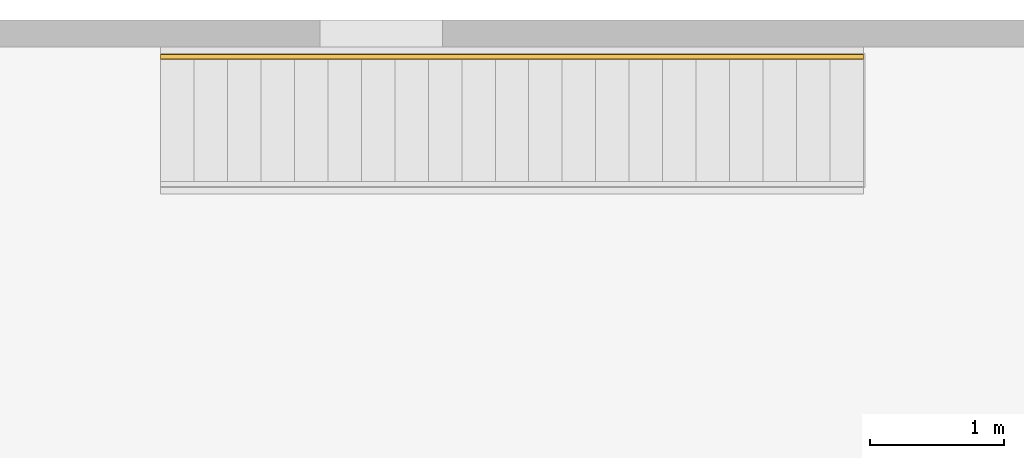
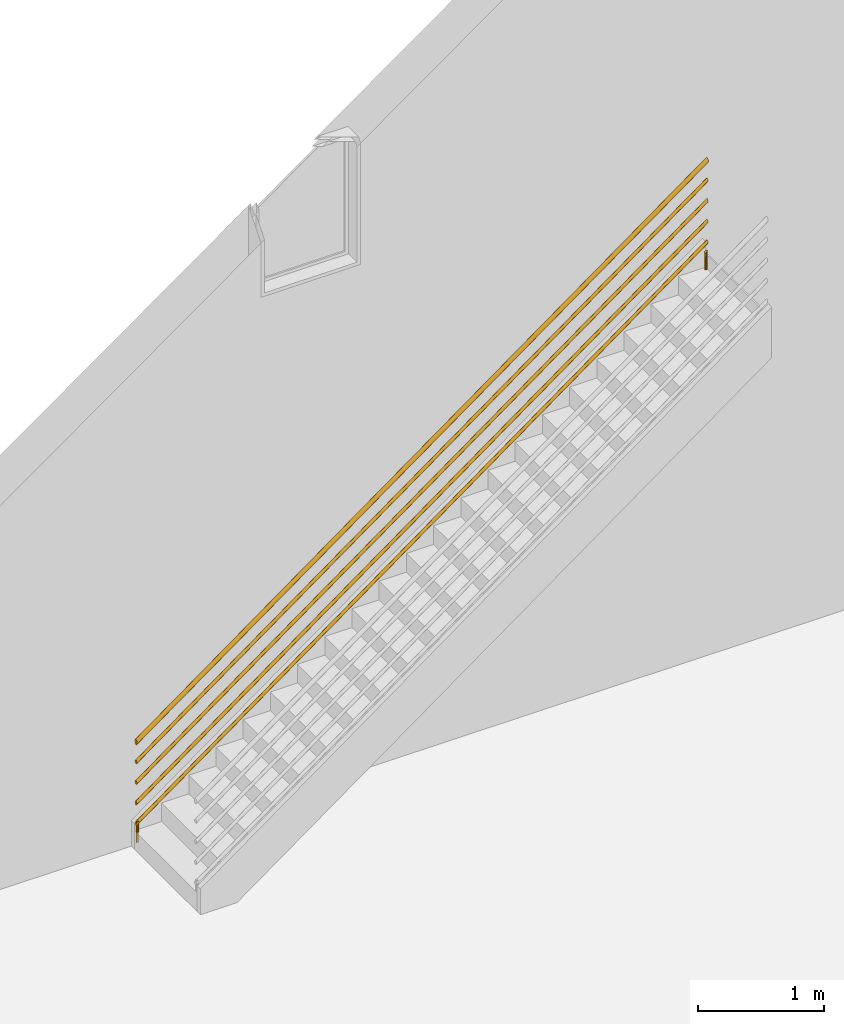
# One storey, part 4 of 4: 1 railing, 1 element without a shape of its own.
"""IFC4 building model written with IfcOpenShell, lengths in millimetres."""

from ifc_helpers import new_model, entity, si_unit, converted_unit, derived_unit, direction, frame, origin, place, context, subcontext, project, spatial, polygons, element, aggregate, save


model = new_model("IFC4")

# Units and contexts
model_context = context("Model", 3, precision=0.01, world=origin(), true_north=direction((6.12303176911189e-17, 1.0)))
body_context = subcontext(model_context, "Body", "Model", "MODEL_VIEW")
ifc_project = project(units=[si_unit("LENGTHUNIT", "METRE", prefix="MILLI"), si_unit("AREAUNIT", "SQUARE_METRE"), si_unit("VOLUMEUNIT", "CUBIC_METRE"), converted_unit("PLANEANGLEUNIT", "DEGREE", entity("IfcRatioMeasure", 0.0174532925199433), si_unit("PLANEANGLEUNIT", "RADIAN"), dimensions=[0, 0, 0, 0, 0, 0, 0]), si_unit("MASSUNIT", "GRAM", prefix="KILO"), derived_unit("MASSDENSITYUNIT", [(si_unit("MASSUNIT", "GRAM", prefix="KILO"), 1), (si_unit("LENGTHUNIT", "METRE"), -3)]), si_unit("TIMEUNIT", "SECOND"), si_unit("FREQUENCYUNIT", "HERTZ"), si_unit("THERMODYNAMICTEMPERATUREUNIT", "DEGREE_CELSIUS"), derived_unit("THERMALTRANSMITTANCEUNIT", [(si_unit("MASSUNIT", "GRAM", prefix="KILO"), 1), (si_unit("THERMODYNAMICTEMPERATUREUNIT", "KELVIN"), -1), (si_unit("TIMEUNIT", "SECOND"), -3)]), derived_unit("VOLUMETRICFLOWRATEUNIT", [(si_unit("LENGTHUNIT", "METRE"), 3), (si_unit("TIMEUNIT", "SECOND"), -1)]), si_unit("ELECTRICCURRENTUNIT", "AMPERE"), si_unit("ELECTRICVOLTAGEUNIT", "VOLT"), si_unit("POWERUNIT", "WATT"), si_unit("FORCEUNIT", "NEWTON", prefix="KILO"), si_unit("ILLUMINANCEUNIT", "LUX"), si_unit("LUMINOUSFLUXUNIT", "LUMEN"), si_unit("LUMINOUSINTENSITYUNIT", "CANDELA"), derived_unit("USERDEFINED", [(si_unit("MASSUNIT", "GRAM", prefix="KILO"), -1), (si_unit("LENGTHUNIT", "METRE"), -2), (si_unit("TIMEUNIT", "SECOND"), 3), (si_unit("LUMINOUSFLUXUNIT", "LUMEN"), 1)]), derived_unit("LINEARVELOCITYUNIT", [(si_unit("LENGTHUNIT", "METRE"), 1), (si_unit("TIMEUNIT", "SECOND"), -1)]), si_unit("PRESSUREUNIT", "PASCAL"), derived_unit("USERDEFINED", [(si_unit("LENGTHUNIT", "METRE"), -2), (si_unit("MASSUNIT", "GRAM", prefix="KILO"), 1), (si_unit("TIMEUNIT", "SECOND"), -2)])], contexts=[model_context])

# Site, building, storey
site_placement = place(None, origin())
site = spatial("IfcSite", under=ifc_project, at=site_placement, CompositionType="ELEMENT")
building_placement = place(site_placement, origin())
building = spatial("IfcBuilding", under=site, at=building_placement, CompositionType="ELEMENT")
storey_placement = place(building_placement, origin())
storey = spatial("IfcBuildingStorey", under=building, at=storey_placement, CompositionType="ELEMENT", Elevation=0.0)

# Stair, railing
stair_placement = place(storey_placement, origin())
stair = element("IfcStair", 1, at=stair_placement, inside=storey, Name="Assembled Stair:Stair", PredefinedType="NOTDEFINED")
railing_placement = place(stair_placement, frame((-1616.29690804862, 3783.31152440017, 81.8181818181819)))
railing = element("IfcRailing", 2, at=railing_placement, Name="Railing:900mm", ObjectType="Railing:900mm", PredefinedType="NOTDEFINED", context=body_context, shape_type="Tessellation", body=[
    polygons([(5238.77409890227, 34.0952722359161, 3909.09090909091), (5244.19764564124, 32.8573830846967, 3913.03530671925), (5248.54699243312, 29.3888947591506, 3916.19846802244), (5250.96069780455, 24.3767839103703, 3917.95389011074), (5250.96069780455, 18.8137605614627, 3917.95389011074), (5248.54699243312, 13.8016497126824, 3916.19846802244), (5244.19764564124, 10.3331613871363, 3913.03530671925), (5238.77409890227, 9.09527223591636, 3909.09090909091), (5238.77409890227, 9.09527223591636, 3736.36363636364), (5245.02409890227, 10.7699546886106, 3736.36363636364), (5249.59941644958, 15.3452722359166, 3736.36363636364), (5251.27409890227, 21.5952722359162, 3736.36363636364), (5249.59941644958, 27.8452722359164, 3736.36363636364), (5245.02409890227, 32.4205897832218, 3736.36363636364), (5238.77409890227, 34.0952722359161, 3736.36363636364), (5232.52409890227, 32.4205897832218, 3736.36363636364), (5227.94878135497, 27.8452722359164, 3736.36363636364), (5226.27409890227, 21.5952722359162, 3736.36363636364), (5227.94878135497, 15.3452722359166, 3736.36363636364), (5232.52409890227, 10.7699546886106, 3736.36363636364), (5233.3505521633, 10.3331613871363, 3905.14651146257), (5229.00120537142, 13.8016497126819, 3901.98335015938), (5226.5875, 18.8137605614622, 3900.22792807107), (5226.5875, 24.3767839103703, 3900.22792807107), (5229.00120537142, 29.3888947591506, 3901.98335015938), (5233.3505521633, 32.8573830846962, 3905.14651146257)], [[[2, 13, 14]], [[2, 14, 1]], [[13, 2, 3]], [[25, 24, 23, 22, 21, 8, 7, 6, 5, 4, 3, 2, 1, 26]], [[13, 3, 4]], [[4, 12, 13]], [[9, 20, 19, 18, 17, 16, 15, 14, 13, 12, 11, 10]], [[1, 14, 15]], [[15, 26, 1]], [[15, 16, 26]], [[4, 5, 12]], [[11, 12, 5]], [[10, 11, 7]], [[6, 11, 5]], [[7, 11, 6]], [[8, 9, 10]], [[7, 8, 10]], [[9, 8, 21]], [[21, 20, 9]], [[22, 19, 20]], [[19, 22, 23]], [[22, 20, 21]], [[23, 24, 18]], [[23, 18, 19]], [[17, 18, 24]], [[16, 17, 25]], [[17, 24, 25]], [[26, 16, 25]]], closed=True),
    polygons([(13.7740989022728, 9.09527223593314, 209.09090909091), (13.7740989022728, 9.09527223593314, -1.69197988952874e-14), (19.1976456412423, 10.3331613871525, -1.69197988952874e-14), (23.5469924331231, 13.8016497126987, -1.69197988952874e-14), (25.9606978045457, 18.813760561479, -1.69197988952874e-14), (25.9606978045457, 24.376783910387, -1.69197988952874e-14), (23.5469924331231, 29.3888947591674, -1.69197988952874e-14), (19.1976456412423, 32.857383084713, -1.69197988952874e-14), (13.7740989022728, 34.0952722359329, -1.69197988952874e-14), (13.7740989022728, 34.0952722359329, 209.09090909091), (19.1976456412423, 32.857383084713, 209.09090909091), (23.5469924331231, 29.3888947591674, 209.09090909091), (25.9606978045457, 24.376783910387, 209.09090909091), (25.9606978045457, 18.813760561479, 209.09090909091), (23.5469924331231, 13.8016497126987, 209.09090909091), (19.1976456412423, 10.3331613871525, 209.09090909091), (8.3505521633033, 32.857383084713, -1.69197988952874e-14), (4.00120537142245, 29.3888947591674, -1.69197988952874e-14), (1.58749999999991, 24.376783910387, -1.69197988952874e-14), (1.58749999999991, 18.813760561479, -1.69197988952874e-14), (4.00120537142245, 13.8016497126987, -1.69197988952874e-14), (8.3505521633033, 10.333161387153, -1.69197988952874e-14), (8.3505521633033, 10.333161387153, 209.09090909091), (4.00120537142245, 13.8016497126987, 209.09090909091), (1.58749999999991, 18.813760561479, 209.09090909091), (1.58749999999991, 24.376783910387, 209.09090909091), (4.00120537142245, 29.3888947591674, 209.09090909091), (8.3505521633033, 32.857383084713, 209.09090909091)], [[[8, 9, 10, 11]], [[7, 8, 11, 12]], [[3, 4, 15, 16]], [[9, 17, 28, 10]], [[26, 25, 24, 23, 1, 16, 15, 14, 13, 12, 11, 10, 28, 27]], [[13, 6, 7, 12]], [[13, 14, 5, 6]], [[4, 5, 14, 15]], [[18, 17, 9, 8, 7, 6, 5, 4, 3, 2, 22, 21, 20, 19]], [[2, 3, 16, 1]], [[22, 2, 1, 23]], [[23, 24, 21, 22]], [[21, 24, 25, 20]], [[25, 26, 19, 20]], [[18, 19, 26, 27]], [[17, 18, 27, 28]]], closed=True),
    polygons([(1.27409890227292, 6.59527223593317, 781.452540215361), (1.27409890227292, 7.10638484159716, 786.252976045899), (1.27409890227292, 8.60489117916664, 790.726270107681), (1.27409890227292, 10.9886705181346, 794.567574802864), (1.27409890227292, 14.0952722359331, 797.515111564529), (1.27409890227292, 17.712986559395, 799.368010633402), (1.27409890227292, 21.595272235933, 800.0), (1.27409890227292, 25.477557912471, 799.368010633402), (1.27409890227292, 29.0952722359329, 797.515111564529), (1.27409890227292, 32.2018739537314, 794.567574802865), (1.27409890227292, 34.5856532926994, 790.726270107681), (1.27409890227292, 36.0841596302689, 786.252976045899), (1.27409890227292, 36.5952722359328, 781.452540215361), (1.27409890227292, 36.0841596302689, 776.652104384824), (1.27409890227292, 34.5856532926999, 772.178810323042), (1.27409890227292, 32.2018739537314, 768.337505627858), (1.27409890227292, 29.0952722359329, 765.389968866194), (1.27409890227292, 25.477557912471, 763.53706979732), (1.27409890227292, 21.595272235933, 762.905080430722), (1.27409890227292, 17.7129865593955, 763.53706979732), (1.27409890227292, 14.0952722359331, 765.389968866193), (1.27409890227292, 10.9886705181346, 768.337505627858), (1.27409890227292, 8.60489117916664, 772.178810323042), (1.27409890227292, 7.10638484159716, 776.652104384823), (5251.27409890227, 6.59527223591639, 4599.63435839718), (5251.27409890227, 7.10638484158038, 4594.83392256664), (5251.27409890227, 8.60489117914986, 4590.36062850486), (5251.27409890227, 10.9886705181179, 4586.51932380968), (5251.27409890227, 14.0952722359163, 4583.57178704801), (5251.27409890227, 17.7129865593788, 4581.71888797914), (5251.27409890227, 21.5952722359162, 4581.08689861254), (5251.27409890227, 25.4775579124542, 4581.71888797914), (5251.27409890227, 29.0952722359161, 4583.57178704801), (5251.27409890227, 32.2018739537146, 4586.51932380968), (5251.27409890227, 34.5856532926831, 4590.36062850486), (5251.27409890227, 36.0841596302521, 4594.83392256664), (5251.27409890227, 36.5952722359161, 4599.63435839718), (5251.27409890227, 36.0841596302521, 4604.43479422772), (5251.27409890227, 34.5856532926826, 4608.9080882895), (5251.27409890227, 32.2018739537146, 4612.74939298468), (5251.27409890227, 29.0952722359161, 4615.69692974635), (5251.27409890227, 25.4775579124542, 4617.54982881522), (5251.27409890227, 21.5952722359162, 4618.18181818182), (5251.27409890227, 17.7129865593782, 4617.54982881522), (5251.27409890227, 14.0952722359163, 4615.69692974635), (5251.27409890227, 10.9886705181179, 4612.74939298468), (5251.27409890227, 8.60489117914986, 4608.9080882895), (5251.27409890227, 7.10638484158038, 4604.43479422772)], [[[13, 12, 38, 37]], [[27, 26, 24, 23]], [[26, 25, 1, 24]], [[36, 35, 15, 14]], [[37, 36, 14, 13]], [[28, 27, 23, 22]], [[34, 33, 17, 16]], [[35, 34, 16, 15]], [[29, 28, 22, 21]], [[33, 32, 18, 17]], [[30, 20, 19, 31]], [[30, 29, 21, 20]], [[48, 2, 1, 25]], [[41, 40, 10, 9]], [[11, 39, 38, 12]], [[10, 40, 39, 11]], [[47, 3, 2, 48]], [[47, 46, 4, 3]], [[5, 4, 46, 45]], [[1, 2, 3, 4, 5, 6, 7, 8, 9, 10, 11, 12, 13, 14, 15, 16, 17, 18, 19, 20, 21, 22, 23, 24]], [[6, 5, 45, 44]], [[7, 6, 44, 43]], [[7, 43, 42, 8]], [[41, 9, 8, 42]], [[31, 19, 18, 32]], [[44, 45, 46, 47, 48, 25, 26, 27, 28, 29, 30, 31, 32, 33, 34, 35, 36, 37, 38, 39, 40, 41, 42, 43]]], closed=True),
    polygons([(1.27409890227292, 6.59527223593317, 581.452540215361), (1.27409890227292, 7.10638484159716, 586.252976045899), (1.27409890227292, 8.60489117916664, 590.726270107681), (1.27409890227292, 10.9886705181346, 594.567574802864), (1.27409890227292, 14.0952722359331, 597.515111564529), (1.27409890227292, 17.712986559395, 599.368010633402), (1.27409890227292, 21.595272235933, 600.0), (1.27409890227292, 25.477557912471, 599.368010633402), (1.27409890227292, 29.0952722359329, 597.515111564529), (1.27409890227292, 32.2018739537314, 594.567574802865), (1.27409890227292, 34.5856532926994, 590.726270107681), (1.27409890227292, 36.0841596302689, 586.252976045899), (1.27409890227292, 36.5952722359328, 581.452540215361), (1.27409890227292, 36.0841596302689, 576.652104384824), (1.27409890227292, 34.5856532926999, 572.178810323042), (1.27409890227292, 32.2018739537314, 568.337505627858), (1.27409890227292, 29.0952722359329, 565.389968866194), (1.27409890227292, 25.477557912471, 563.53706979732), (1.27409890227292, 21.595272235933, 562.905080430722), (1.27409890227292, 17.7129865593955, 563.53706979732), (1.27409890227292, 14.0952722359331, 565.389968866193), (1.27409890227292, 10.9886705181346, 568.337505627858), (1.27409890227292, 8.60489117916664, 572.178810323042), (1.27409890227292, 7.10638484159716, 576.652104384823), (5251.27409890227, 6.59527223591639, 4399.63435839718), (5251.27409890227, 7.10638484158038, 4394.83392256664), (5251.27409890227, 8.60489117914986, 4390.36062850486), (5251.27409890227, 10.9886705181179, 4386.51932380968), (5251.27409890227, 14.0952722359163, 4383.57178704801), (5251.27409890227, 17.7129865593788, 4381.71888797914), (5251.27409890227, 21.5952722359162, 4381.08689861254), (5251.27409890227, 25.4775579124542, 4381.71888797914), (5251.27409890227, 29.0952722359161, 4383.57178704801), (5251.27409890227, 32.2018739537146, 4386.51932380968), (5251.27409890227, 34.5856532926831, 4390.36062850486), (5251.27409890227, 36.0841596302521, 4394.83392256664), (5251.27409890227, 36.5952722359161, 4399.63435839718), (5251.27409890227, 36.0841596302521, 4404.43479422772), (5251.27409890227, 34.5856532926826, 4408.9080882895), (5251.27409890227, 32.2018739537146, 4412.74939298468), (5251.27409890227, 29.0952722359161, 4415.69692974635), (5251.27409890227, 25.4775579124542, 4417.54982881522), (5251.27409890227, 21.5952722359162, 4418.18181818182), (5251.27409890227, 17.7129865593782, 4417.54982881522), (5251.27409890227, 14.0952722359163, 4415.69692974635), (5251.27409890227, 10.9886705181179, 4412.74939298468), (5251.27409890227, 8.60489117914986, 4408.9080882895), (5251.27409890227, 7.10638484158038, 4404.43479422772)], [[[13, 12, 38, 37]], [[27, 26, 24, 23]], [[26, 25, 1, 24]], [[36, 35, 15, 14]], [[37, 36, 14, 13]], [[28, 27, 23, 22]], [[34, 33, 17, 16]], [[35, 34, 16, 15]], [[29, 28, 22, 21]], [[33, 32, 18, 17]], [[30, 20, 19, 31]], [[30, 29, 21, 20]], [[48, 2, 1, 25]], [[41, 40, 10, 9]], [[11, 39, 38, 12]], [[10, 40, 39, 11]], [[47, 3, 2, 48]], [[47, 46, 4, 3]], [[5, 4, 46, 45]], [[1, 2, 3, 4, 5, 6, 7, 8, 9, 10, 11, 12, 13, 14, 15, 16, 17, 18, 19, 20, 21, 22, 23, 24]], [[6, 5, 45, 44]], [[7, 6, 44, 43]], [[7, 43, 42, 8]], [[41, 9, 8, 42]], [[31, 19, 18, 32]], [[44, 45, 46, 47, 48, 25, 26, 27, 28, 29, 30, 31, 32, 33, 34, 35, 36, 37, 38, 39, 40, 41, 42, 43]]], closed=True),
    polygons([(1.27409890227292, 6.59527223593317, 381.452540215361), (1.27409890227292, 7.10638484159716, 386.252976045899), (1.27409890227292, 8.60489117916664, 390.726270107681), (1.27409890227292, 10.9886705181346, 394.567574802864), (1.27409890227292, 14.0952722359331, 397.515111564529), (1.27409890227292, 17.712986559395, 399.368010633402), (1.27409890227292, 21.595272235933, 400.0), (1.27409890227292, 25.477557912471, 399.368010633402), (1.27409890227292, 29.0952722359329, 397.515111564529), (1.27409890227292, 32.2018739537314, 394.567574802864), (1.27409890227292, 34.5856532926994, 390.726270107681), (1.27409890227292, 36.0841596302689, 386.252976045899), (1.27409890227292, 36.5952722359328, 381.452540215361), (1.27409890227292, 36.0841596302689, 376.652104384824), (1.27409890227292, 34.5856532926999, 372.178810323041), (1.27409890227292, 32.2018739537314, 368.337505627858), (1.27409890227292, 29.0952722359329, 365.389968866193), (1.27409890227292, 25.477557912471, 363.53706979732), (1.27409890227292, 21.595272235933, 362.905080430722), (1.27409890227292, 17.7129865593955, 363.53706979732), (1.27409890227292, 14.0952722359331, 365.389968866193), (1.27409890227292, 10.9886705181346, 368.337505627858), (1.27409890227292, 8.60489117916664, 372.178810323041), (1.27409890227292, 7.10638484159716, 376.652104384823), (5251.27409890227, 6.59527223591639, 4199.63435839718), (5251.27409890227, 7.10638484158038, 4194.83392256664), (5251.27409890227, 8.60489117914986, 4190.36062850486), (5251.27409890227, 10.9886705181179, 4186.51932380968), (5251.27409890227, 14.0952722359163, 4183.57178704801), (5251.27409890227, 17.7129865593788, 4181.71888797914), (5251.27409890227, 21.5952722359162, 4181.08689861254), (5251.27409890227, 25.4775579124542, 4181.71888797914), (5251.27409890227, 29.0952722359161, 4183.57178704801), (5251.27409890227, 32.2018739537146, 4186.51932380968), (5251.27409890227, 34.5856532926831, 4190.36062850486), (5251.27409890227, 36.0841596302521, 4194.83392256664), (5251.27409890227, 36.5952722359161, 4199.63435839718), (5251.27409890227, 36.0841596302521, 4204.43479422772), (5251.27409890227, 34.5856532926826, 4208.9080882895), (5251.27409890227, 32.2018739537146, 4212.74939298468), (5251.27409890227, 29.0952722359161, 4215.69692974635), (5251.27409890227, 25.4775579124542, 4217.54982881522), (5251.27409890227, 21.5952722359162, 4218.18181818182), (5251.27409890227, 17.7129865593782, 4217.54982881522), (5251.27409890227, 14.0952722359163, 4215.69692974635), (5251.27409890227, 10.9886705181179, 4212.74939298468), (5251.27409890227, 8.60489117914986, 4208.9080882895), (5251.27409890227, 7.10638484158038, 4204.43479422772)], [[[13, 12, 38, 37]], [[27, 26, 24, 23]], [[26, 25, 1, 24]], [[36, 35, 15, 14]], [[37, 36, 14, 13]], [[28, 27, 23, 22]], [[34, 33, 17, 16]], [[35, 34, 16, 15]], [[29, 28, 22, 21]], [[33, 32, 18, 17]], [[30, 20, 19, 31]], [[30, 29, 21, 20]], [[48, 2, 1, 25]], [[6, 7, 8, 9, 10, 11, 12, 13, 14, 15, 16, 17, 18, 19, 20, 21, 22, 23, 24, 1, 2, 3, 4, 5]], [[11, 39, 38, 12]], [[10, 40, 39, 11]], [[47, 3, 2, 48]], [[47, 46, 4, 3]], [[5, 4, 46, 45]], [[41, 40, 10, 9]], [[6, 5, 45, 44]], [[7, 6, 44, 43]], [[41, 9, 8, 42]], [[31, 19, 18, 32]], [[7, 43, 42, 8]], [[44, 45, 46, 47, 48, 25, 26, 27, 28, 29, 30, 31, 32, 33, 34, 35, 36, 37, 38, 39, 40, 41, 42, 43]]], closed=True),
    polygons([(1.27409890227292, 6.59527223593371, 181.452540215361), (1.27409890227292, 7.10638484159771, 186.252976045899), (1.27409890227292, 8.60489117916718, 190.726270107681), (1.27409890227292, 10.9886705181352, 194.567574802864), (1.27409890227292, 14.0952722359336, 197.515111564529), (1.27409890227292, 17.7129865593955, 199.368010633402), (1.27409890227292, 21.5952722359336, 200.0), (1.27409890227292, 25.4775579124716, 199.368010633402), (1.27409890227292, 29.0952722359335, 197.515111564529), (1.27409890227292, 32.2018739537319, 194.567574802864), (1.27409890227292, 34.5856532926999, 190.726270107681), (1.27409890227292, 36.0841596302694, 186.252976045899), (1.27409890227292, 36.5952722359334, 181.452540215361), (1.27409890227292, 36.0841596302694, 176.652104384823), (1.27409890227292, 34.5856532927005, 172.178810323041), (1.27409890227292, 32.2018739537319, 168.337505627858), (1.27409890227292, 29.0952722359335, 165.389968866193), (1.27409890227292, 25.4775579124716, 163.53706979732), (1.27409890227292, 21.5952722359336, 162.905080430722), (1.27409890227292, 17.7129865593961, 163.53706979732), (1.27409890227292, 14.0952722359336, 165.389968866193), (1.27409890227292, 10.9886705181352, 168.337505627858), (1.27409890227292, 8.60489117916718, 172.178810323041), (1.27409890227292, 7.10638484159771, 176.652104384823), (5251.27409890227, 6.59527223591693, 3999.63435839718), (5251.27409890227, 7.10638484158092, 3994.83392256664), (5251.27409890227, 8.6048911791504, 3990.36062850486), (5251.27409890227, 10.9886705181184, 3986.51932380968), (5251.27409890227, 14.0952722359168, 3983.57178704801), (5251.27409890227, 17.7129865593793, 3981.71888797914), (5251.27409890227, 21.5952722359168, 3981.08689861254), (5251.27409890227, 25.4775579124548, 3981.71888797914), (5251.27409890227, 29.0952722359167, 3983.57178704801), (5251.27409890227, 32.2018739537151, 3986.51932380968), (5251.27409890227, 34.5856532926837, 3990.36062850486), (5251.27409890227, 36.0841596302526, 3994.83392256664), (5251.27409890227, 36.5952722359166, 3999.63435839718), (5251.27409890227, 36.0841596302526, 4004.43479422772), (5251.27409890227, 34.5856532926831, 4008.9080882895), (5251.27409890227, 32.2018739537151, 4012.74939298468), (5251.27409890227, 29.0952722359167, 4015.69692974635), (5251.27409890227, 25.4775579124548, 4017.54982881522), (5251.27409890227, 21.5952722359168, 4018.18181818182), (5251.27409890227, 17.7129865593788, 4017.54982881522), (5251.27409890227, 14.0952722359168, 4015.69692974635), (5251.27409890227, 10.9886705181184, 4012.74939298468), (5251.27409890227, 8.6048911791504, 4008.9080882895), (5251.27409890227, 7.10638484158092, 4004.43479422772)], [[[13, 12, 38, 37]], [[27, 26, 24, 23]], [[26, 25, 1, 24]], [[36, 35, 15, 14]], [[37, 36, 14, 13]], [[28, 27, 23, 22]], [[34, 33, 17, 16]], [[35, 34, 16, 15]], [[29, 28, 22, 21]], [[33, 32, 18, 17]], [[30, 20, 19, 31]], [[30, 29, 21, 20]], [[48, 2, 1, 25]], [[31, 19, 18, 32]], [[11, 39, 38, 12]], [[10, 40, 39, 11]], [[47, 3, 2, 48]], [[47, 46, 4, 3]], [[5, 4, 46, 45]], [[1, 2, 3, 4, 5, 6, 7, 8, 9, 10, 11, 12, 13, 14, 15, 16, 17, 18, 19, 20, 21, 22, 23, 24]], [[6, 5, 45, 44]], [[7, 6, 44, 43]], [[41, 40, 10, 9]], [[41, 9, 8, 42]], [[7, 43, 42, 8]], [[44, 45, 46, 47, 48, 25, 26, 27, 28, 29, 30, 31, 32, 33, 34, 35, 36, 37, 38, 39, 40, 41, 42, 43]]], closed=True),
    polygons([(1.27409890227292, 1.59527223593323, 975.270053620481), (1.27409890227292, 2.27675571015188, 981.670634727865), (1.27409890227292, 4.27476416024398, 987.635026810241), (1.27409890227292, 7.4531366122022, 992.756766403819), (1.27409890227292, 11.5952722359331, 996.686815419372), (1.27409890227292, 16.4188913338827, 999.157347511202), (1.27409890227292, 21.595272235933, 1000.0), (1.27409890227292, 26.7716531379833, 999.157347511202), (1.27409890227292, 31.5952722359329, 996.686815419372), (1.27409890227292, 35.7374078596638, 992.756766403819), (1.27409890227292, 38.9157803116215, 987.635026810241), (1.27409890227292, 40.9137887617141, 981.670634727865), (1.27409890227292, 41.5952722359328, 975.270053620481), (1.27409890227292, 40.9137887617147, 968.869472513098), (1.27409890227292, 38.915780311622, 962.905080430722), (1.27409890227292, 35.7374078596644, 957.783340837144), (1.27409890227292, 31.5952722359329, 953.853291821591), (1.27409890227292, 26.7716531379833, 951.38275972976), (1.27409890227292, 21.595272235933, 950.540107240962), (1.27409890227292, 16.4188913338827, 951.38275972976), (1.27409890227292, 11.5952722359331, 953.853291821591), (1.27409890227292, 7.4531366122022, 957.783340837144), (1.27409890227292, 4.27476416024452, 962.905080430721), (1.27409890227292, 2.27675571015188, 968.869472513097), (5251.27409890227, 1.59527223591644, 4793.4518718023), (5251.27409890227, 2.2767557101351, 4787.05129069492), (5251.27409890227, 4.27476416022773, 4781.08689861254), (5251.27409890227, 7.45313661218542, 4775.96515901896), (5251.27409890227, 11.5952722359163, 4772.03511000341), (5251.27409890227, 16.4188913338659, 4769.56457791158), (5251.27409890227, 21.5952722359162, 4768.72192542278), (5251.27409890227, 26.7716531379665, 4769.56457791158), (5251.27409890227, 31.5952722359161, 4772.03511000341), (5251.27409890227, 35.7374078596476, 4775.96515901896), (5251.27409890227, 38.9157803116053, 4781.08689861254), (5251.27409890227, 40.9137887616979, 4787.05129069492), (5251.27409890227, 41.595272235916, 4793.4518718023), (5251.27409890227, 40.9137887616974, 4799.85245290968), (5251.27409890227, 38.9157803116047, 4805.81684499206), (5251.27409890227, 35.737407859647, 4810.93858458564), (5251.27409890227, 31.5952722359161, 4814.86863360119), (5251.27409890227, 26.7716531379665, 4817.33916569302), (5251.27409890227, 21.5952722359162, 4818.18181818182), (5251.27409890227, 16.4188913338659, 4817.33916569302), (5251.27409890227, 11.5952722359163, 4814.86863360119), (5251.27409890227, 7.45313661218542, 4810.93858458564), (5251.27409890227, 4.27476416022719, 4805.81684499206), (5251.27409890227, 2.2767557101351, 4799.85245290968)], [[[20, 21, 22, 23, 24, 1, 2, 3, 4, 5, 6, 7, 8, 9, 10, 11, 12, 13, 14, 15, 16, 17, 18, 19]], [[27, 26, 24, 23]], [[26, 25, 1, 24]], [[35, 34, 16, 15]], [[36, 35, 15, 14]], [[28, 27, 23, 22]], [[34, 33, 17, 16]], [[29, 28, 22, 21]], [[33, 32, 18, 17]], [[30, 20, 19, 31]], [[30, 29, 21, 20]], [[13, 12, 38, 37]], [[37, 36, 14, 13]], [[48, 2, 1, 25]], [[41, 40, 10, 9]], [[11, 39, 38, 12]], [[10, 40, 39, 11]], [[47, 3, 2, 48]], [[47, 46, 4, 3]], [[5, 4, 46, 45]], [[6, 5, 45, 44]], [[7, 6, 44, 43]], [[7, 43, 42, 8]], [[41, 9, 8, 42]], [[31, 19, 18, 32]], [[44, 45, 46, 47, 48, 25, 26, 27, 28, 29, 30, 31, 32, 33, 34, 35, 36, 37, 38, 39, 40, 41, 42, 43]]], closed=True),
])
aggregate(stair, [railing])

save(model, "model.ifc")
